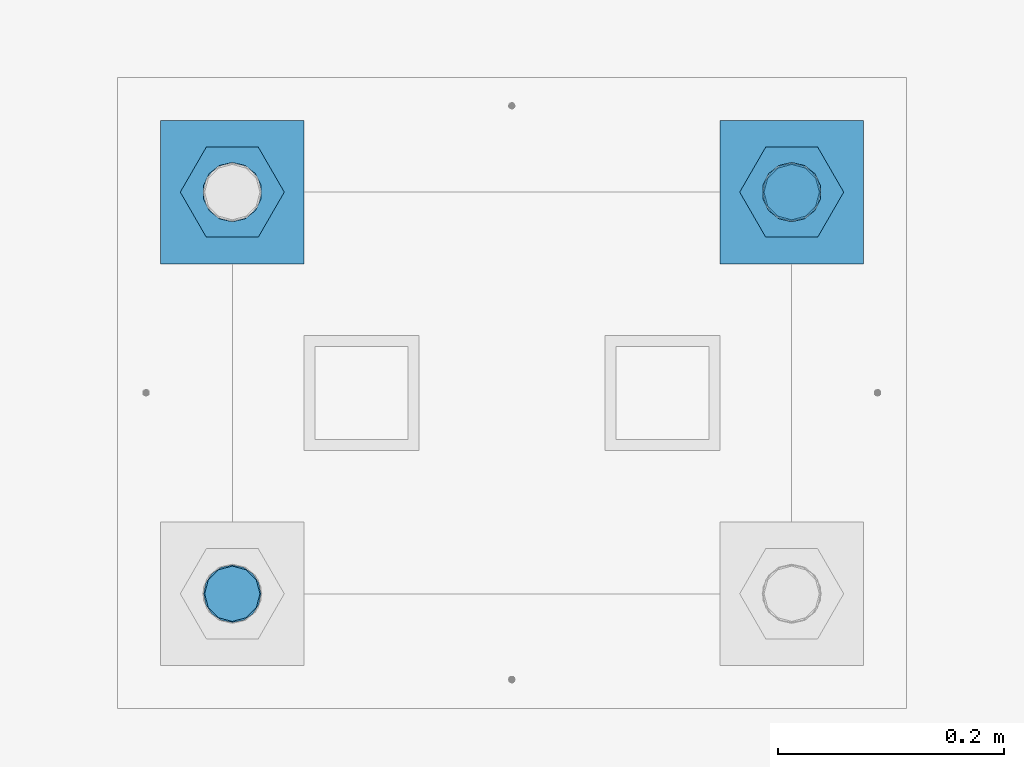
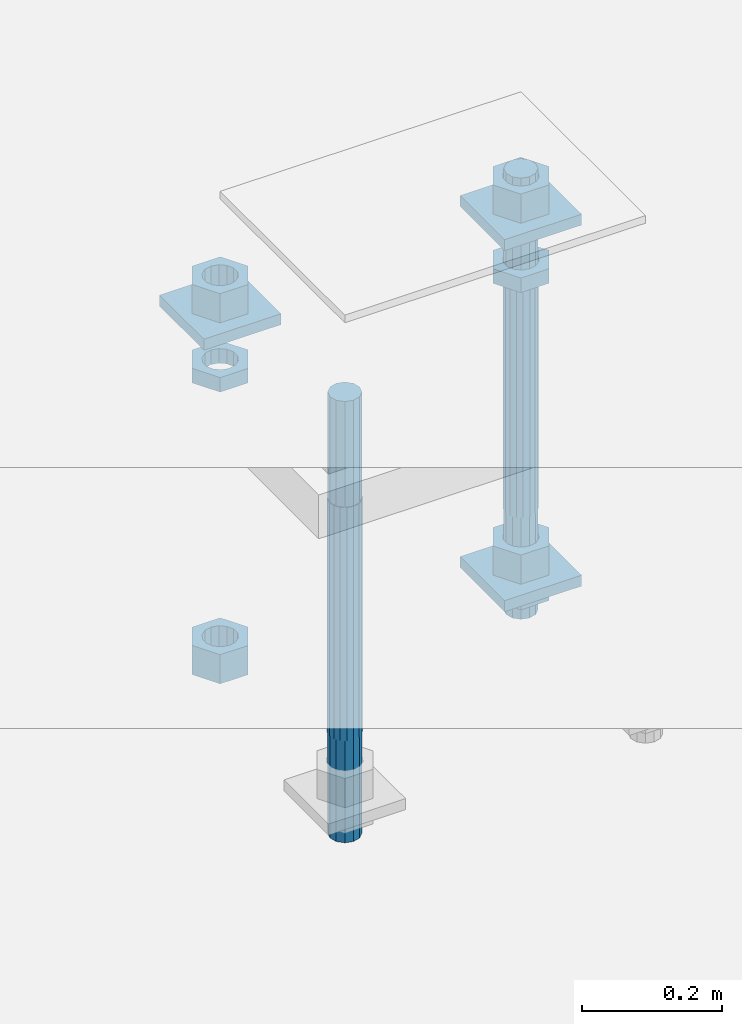
# One storey, part 2595 of 3843: 12 beams, 1 element without a shape of its own.
"""IFC2X3 building model written with IfcOpenShell, lengths in millimetres."""

from ifc_helpers import new_model, si_unit, frame, origin_with_axes, place, context, subcontext, project, spatial, faceted_brep, material, type_object, element, aggregate, save


model = new_model("IFC2X3")

# Units and contexts
model_context = context("Model", 3, precision=1e-05, world=origin_with_axes())
body_context = subcontext(model_context, "Body", "Model", "MODEL_VIEW")
ifc_project = project(units=[si_unit("LENGTHUNIT", "METRE", prefix="MILLI"), si_unit("AREAUNIT", "SQUARE_METRE"), si_unit("VOLUMEUNIT", "CUBIC_METRE"), si_unit("MASSUNIT", "GRAM", prefix="KILO"), si_unit("TIMEUNIT", "SECOND"), si_unit("PLANEANGLEUNIT", "RADIAN"), si_unit("SOLIDANGLEUNIT", "STERADIAN"), si_unit("THERMODYNAMICTEMPERATUREUNIT", "DEGREE_CELSIUS"), si_unit("LUMINOUSINTENSITYUNIT", "LUMEN")], contexts=[model_context])

# Site, building, storey
site_placement = place(None, origin_with_axes())
site = spatial("IfcSite", under=ifc_project, at=site_placement, CompositionType="ELEMENT")
building_placement = place(site_placement, origin_with_axes())
building = spatial("IfcBuilding", under=site, at=building_placement, Name="Undefined", CompositionType="ELEMENT")
storey_placement = place(building_placement, origin_with_axes())
storey = spatial("IfcBuildingStorey", under=building, at=storey_placement, Name="Undefined", CompositionType="ELEMENT", Elevation=0.0)

# Assembly, beams
assembly_placement = place(storey_placement, origin_with_axes())
assembly = element("IfcElementAssembly", 1, at=assembly_placement, inside=storey, Name="TEMPLATE", AssemblyPlace="NOTDEFINED", PredefinedType="RIGID_FRAME")
ifc_material_1 = material(Name="STEEL/A572-50")
beam_type_1 = type_object("IfcBeamType", PredefinedType="NOTDEFINED")
beam_1_placement = place(assembly_placement, frame((105403.65, 17957.7999984741, 29873.575), z_axis=(-1.0, 0.0, 0.0), x_axis=(0.0, -1.0, 0.0)))
beam_1 = element("IfcBeam", 2, at=beam_1_placement, type_object=beam_type_1, material=ifc_material_1, Name="WASHER_PLATE", context=body_context, shape_type="Brep", body=[
    faceted_brep([(0.0, 9.52500000000146, -63.5), (0.0, 9.52500000000146, 63.5), (127.0, 9.52500000000146, 63.5), (127.0, 9.52500000000146, -63.5), (0.0, -9.52500000000146, 63.5), (127.0, -9.52500000000146, 63.5), (0.0, -9.52500000000146, -63.5), (127.0, -9.52500000000146, -63.5)], [[[0, 1, 2, 3]], [[1, 4, 5, 2]], [[4, 6, 7, 5]], [[6, 0, 3, 7]], [[5, 7, 3, 2]], [[6, 4, 1, 0]]]),
])
beam_2_placement = place(assembly_placement, frame((104908.35, 17957.7999984741, 29873.575), z_axis=(-1.0, 0.0, 0.0), x_axis=(0.0, -1.0, 0.0)))
beam_2 = element("IfcBeam", 3, at=beam_2_placement, type_object=beam_type_1, material=ifc_material_1, Name="WASHER_PLATE", context=body_context, shape_type="Brep", body=[
    faceted_brep([(0.0, 9.52500000000146, -63.5), (0.0, 9.52500000000146, 63.5), (127.0, 9.52500000000146, 63.5), (127.0, 9.52500000000146, -63.5), (0.0, -9.52500000000146, 63.5), (127.0, -9.52500000000146, 63.5), (0.0, -9.52500000000146, -63.5), (127.0, -9.52500000000146, -63.5)], [[[0, 1, 2, 3]], [[1, 4, 5, 2]], [[4, 6, 7, 5]], [[6, 0, 3, 7]], [[5, 7, 3, 2]], [[6, 4, 1, 0]]]),
])
beam_3_placement = place(assembly_placement, frame((105403.65, 17957.7999984741, 29244.925), z_axis=(-1.0, 0.0, 0.0), x_axis=(0.0, -1.0, 0.0)))
beam_3 = element("IfcBeam", 4, at=beam_3_placement, type_object=beam_type_1, material=ifc_material_1, Name="WASHER_PLATE", context=body_context, shape_type="Brep", body=[
    faceted_brep([(0.0, 9.52500000000146, -63.5), (0.0, 9.52500000000146, 63.5), (127.0, 9.52500000000146, 63.5), (127.0, 9.52500000000146, -63.5), (0.0, -9.52500000000146, 63.5), (127.0, -9.52500000000146, 63.5), (0.0, -9.52500000000146, -63.5), (127.0, -9.52500000000146, -63.5)], [[[0, 1, 2, 3]], [[1, 4, 5, 2]], [[4, 6, 7, 5]], [[6, 0, 3, 7]], [[5, 7, 3, 2]], [[6, 4, 1, 0]]]),
])
ifc_material_2 = material(Name="STEEL/A36")
beam_type_2 = type_object("IfcBeamType", Name="2_HALF_NUT", PredefinedType="NOTDEFINED")
beam_4_placement = place(assembly_placement, frame((105403.65, 17894.2999984741, 29787.85), z_axis=(0.0, -1.0, 0.0), x_axis=(0.0, 0.0, -1.0)))
beam_4 = element("IfcBeam", 5, at=beam_4_placement, type_object=beam_type_2, material=ifc_material_2, Name="NUT", ObjectType="2_HALF_NUT", context=body_context, shape_type="Brep", body=[
    faceted_brep([(0.0, -46.0369987487793, 0.0), (0.0, -23.0184993743896, -39.869213104248), (25.4000000000015, -23.0184993743896, -39.869213104248), (25.4000000000015, -46.0369987487793, 0.0), (0.0, 23.0184993743896, -39.869213104248), (25.4000000000015, 23.0184993743896, -39.869213104248), (0.0, 46.0369987487793, 0.0), (25.4000000000015, 46.0369987487793, 0.0), (0.0, 23.0184993743896, 39.869213104248), (25.4000000000015, 23.0184993743896, 39.869213104248), (0.0, -23.0184993743896, 39.869213104248), (25.4000000000015, -23.0184993743896, 39.869213104248), (0.0, 0.0, 26.1940002441406), (0.0, 11.3650617044477, 23.5999013092805), (25.4000000000015, 11.3650617044477, 23.5999013092805), (25.4000000000015, 0.0, 26.1940002441406), (0.0, 20.4791109456419, 16.3316083006721), (25.4000000000015, 20.4791109456419, 16.3316083006721), (0.0, 25.5370200498292, 5.82867859874386), (25.4000000000015, 25.5370200498292, 5.82867859874386), (0.0, 25.5370200498292, -5.82867859874386), (25.4000000000015, 25.5370200498292, -5.82867859874386), (0.0, 20.4791109456419, -16.3316083006721), (25.4000000000015, 20.4791109456419, -16.3316083006721), (0.0, 11.3650617044477, -23.5999013092805), (25.4000000000015, 11.3650617044477, -23.5999013092805), (0.0, 0.0, -26.1940002441406), (25.4000000000015, 0.0, -26.1940002441406), (0.0, -11.3650617044477, -23.5999013092805), (25.4000000000015, -11.3650617044477, -23.5999013092805), (0.0, -20.4791109456419, -16.3316083006721), (25.4000000000015, -20.4791109456419, -16.3316083006721), (0.0, -25.5370200498292, -5.82867859874386), (25.4000000000015, -25.5370200498292, -5.82867859874386), (0.0, -25.5370200498292, 5.82867859874386), (25.4000000000015, -25.5370200498292, 5.82867859874386), (0.0, -20.4791109456419, 16.3316083006721), (25.4000000000015, -20.4791109456419, 16.3316083006721), (0.0, -11.3650617044477, 23.5999013092805), (25.4000000000015, -11.3650617044477, 23.5999013092805)], [[[0, 1, 2, 3]], [[1, 4, 5, 2]], [[4, 6, 7, 5]], [[6, 8, 9, 7]], [[8, 10, 11, 9]], [[10, 0, 3, 11]], [[12, 13, 14, 15]], [[13, 16, 17, 14]], [[16, 18, 19, 17]], [[18, 20, 21, 19]], [[20, 22, 23, 21]], [[22, 24, 25, 23]], [[24, 26, 27, 25]], [[26, 28, 29, 27]], [[28, 30, 31, 29]], [[30, 32, 33, 31]], [[32, 34, 35, 33]], [[34, 36, 37, 35]], [[36, 38, 39, 37]], [[38, 12, 15, 39]], [[5, 7, 9, 11, 3, 2], [17, 19, 21, 23, 25, 27, 29, 31, 33, 35, 37, 39, 15, 14]], [[10, 8, 6, 4, 1, 0], [38, 36, 34, 32, 30, 28, 26, 24, 22, 20, 18, 16, 13, 12]]]),
])
beam_5_placement = place(assembly_placement, frame((105403.65, 17894.2999984741, 29235.4), z_axis=(0.0, -1.0, 0.0), x_axis=(0.0, 0.0, -1.0)))
beam_5 = element("IfcBeam", 6, at=beam_5_placement, type_object=beam_type_2, material=ifc_material_2, Name="NUT", ObjectType="2_HALF_NUT", context=body_context, shape_type="Brep", body=[
    faceted_brep([(0.0, -46.0369987487793, 0.0), (0.0, -23.0184993743896, -39.869213104248), (25.4000000000015, -23.0184993743896, -39.869213104248), (25.4000000000015, -46.0369987487793, 0.0), (0.0, 23.0184993743896, -39.869213104248), (25.4000000000015, 23.0184993743896, -39.869213104248), (0.0, 46.0369987487793, 0.0), (25.4000000000015, 46.0369987487793, 0.0), (0.0, 23.0184993743896, 39.869213104248), (25.4000000000015, 23.0184993743896, 39.869213104248), (0.0, -23.0184993743896, 39.869213104248), (25.4000000000015, -23.0184993743896, 39.869213104248), (0.0, 0.0, 26.1940002441406), (0.0, 11.3650617044477, 23.5999013092805), (25.4000000000015, 11.3650617044477, 23.5999013092805), (25.4000000000015, 0.0, 26.1940002441406), (0.0, 20.4791109456419, 16.3316083006721), (25.4000000000015, 20.4791109456419, 16.3316083006721), (0.0, 25.5370200498292, 5.82867859874386), (25.4000000000015, 25.5370200498292, 5.82867859874386), (0.0, 25.5370200498292, -5.82867859874386), (25.4000000000015, 25.5370200498292, -5.82867859874386), (0.0, 20.4791109456419, -16.3316083006721), (25.4000000000015, 20.4791109456419, -16.3316083006721), (0.0, 11.3650617044477, -23.5999013092805), (25.4000000000015, 11.3650617044477, -23.5999013092805), (0.0, 0.0, -26.1940002441406), (25.4000000000015, 0.0, -26.1940002441406), (0.0, -11.3650617044477, -23.5999013092805), (25.4000000000015, -11.3650617044477, -23.5999013092805), (0.0, -20.4791109456419, -16.3316083006721), (25.4000000000015, -20.4791109456419, -16.3316083006721), (0.0, -25.5370200498292, -5.82867859874386), (25.4000000000015, -25.5370200498292, -5.82867859874386), (0.0, -25.5370200498292, 5.82867859874386), (25.4000000000015, -25.5370200498292, 5.82867859874386), (0.0, -20.4791109456419, 16.3316083006721), (25.4000000000015, -20.4791109456419, 16.3316083006721), (0.0, -11.3650617044477, 23.5999013092805), (25.4000000000015, -11.3650617044477, 23.5999013092805)], [[[0, 1, 2, 3]], [[1, 4, 5, 2]], [[4, 6, 7, 5]], [[6, 8, 9, 7]], [[8, 10, 11, 9]], [[10, 0, 3, 11]], [[12, 13, 14, 15]], [[13, 16, 17, 14]], [[16, 18, 19, 17]], [[18, 20, 21, 19]], [[20, 22, 23, 21]], [[22, 24, 25, 23]], [[24, 26, 27, 25]], [[26, 28, 29, 27]], [[28, 30, 31, 29]], [[30, 32, 33, 31]], [[32, 34, 35, 33]], [[34, 36, 37, 35]], [[36, 38, 39, 37]], [[38, 12, 15, 39]], [[5, 7, 9, 11, 3, 2], [17, 19, 21, 23, 25, 27, 29, 31, 33, 35, 37, 39, 15, 14]], [[10, 8, 6, 4, 1, 0], [38, 36, 34, 32, 30, 28, 26, 24, 22, 20, 18, 16, 13, 12]]]),
])
beam_6_placement = place(assembly_placement, frame((104908.35, 17894.2999984741, 29787.85), z_axis=(0.0, -1.0, 0.0), x_axis=(0.0, 0.0, -1.0)))
beam_6 = element("IfcBeam", 7, at=beam_6_placement, type_object=beam_type_2, material=ifc_material_2, Name="NUT", ObjectType="2_HALF_NUT", context=body_context, shape_type="Brep", body=[
    faceted_brep([(0.0, -46.0369987487793, 0.0), (0.0, -23.0184993743896, -39.869213104248), (25.4000000000015, -23.0184993743896, -39.869213104248), (25.4000000000015, -46.0369987487793, 0.0), (0.0, 23.0184993743896, -39.869213104248), (25.4000000000015, 23.0184993743896, -39.869213104248), (0.0, 46.0369987487793, 0.0), (25.4000000000015, 46.0369987487793, 0.0), (0.0, 23.0184993743896, 39.869213104248), (25.4000000000015, 23.0184993743896, 39.869213104248), (0.0, -23.0184993743896, 39.869213104248), (25.4000000000015, -23.0184993743896, 39.869213104248), (0.0, 0.0, 26.1940002441406), (0.0, 11.3650617044477, 23.5999013092805), (25.4000000000015, 11.3650617044477, 23.5999013092805), (25.4000000000015, 0.0, 26.1940002441406), (0.0, 20.4791109456419, 16.3316083006721), (25.4000000000015, 20.4791109456419, 16.3316083006721), (0.0, 25.5370200498292, 5.82867859874386), (25.4000000000015, 25.5370200498292, 5.82867859874386), (0.0, 25.5370200498292, -5.82867859874386), (25.4000000000015, 25.5370200498292, -5.82867859874386), (0.0, 20.4791109456419, -16.3316083006721), (25.4000000000015, 20.4791109456419, -16.3316083006721), (0.0, 11.3650617044477, -23.5999013092805), (25.4000000000015, 11.3650617044477, -23.5999013092805), (0.0, 0.0, -26.1940002441406), (25.4000000000015, 0.0, -26.1940002441406), (0.0, -11.3650617044477, -23.5999013092805), (25.4000000000015, -11.3650617044477, -23.5999013092805), (0.0, -20.4791109456419, -16.3316083006721), (25.4000000000015, -20.4791109456419, -16.3316083006721), (0.0, -25.5370200498292, -5.82867859874386), (25.4000000000015, -25.5370200498292, -5.82867859874386), (0.0, -25.5370200498292, 5.82867859874386), (25.4000000000015, -25.5370200498292, 5.82867859874386), (0.0, -20.4791109456419, 16.3316083006721), (25.4000000000015, -20.4791109456419, 16.3316083006721), (0.0, -11.3650617044477, 23.5999013092805), (25.4000000000015, -11.3650617044477, 23.5999013092805)], [[[0, 1, 2, 3]], [[1, 4, 5, 2]], [[4, 6, 7, 5]], [[6, 8, 9, 7]], [[8, 10, 11, 9]], [[10, 0, 3, 11]], [[12, 13, 14, 15]], [[13, 16, 17, 14]], [[16, 18, 19, 17]], [[18, 20, 21, 19]], [[20, 22, 23, 21]], [[22, 24, 25, 23]], [[24, 26, 27, 25]], [[26, 28, 29, 27]], [[28, 30, 31, 29]], [[30, 32, 33, 31]], [[32, 34, 35, 33]], [[34, 36, 37, 35]], [[36, 38, 39, 37]], [[38, 12, 15, 39]], [[5, 7, 9, 11, 3, 2], [17, 19, 21, 23, 25, 27, 29, 31, 33, 35, 37, 39, 15, 14]], [[10, 8, 6, 4, 1, 0], [38, 36, 34, 32, 30, 28, 26, 24, 22, 20, 18, 16, 13, 12]]]),
])
beam_type_3 = type_object("IfcBeamType", Name="2_HEAVY_HEX_NUT", PredefinedType="NOTDEFINED")
beam_7_placement = place(assembly_placement, frame((105403.65, 17894.2999984741, 29933.9), z_axis=(0.0, -1.0, 0.0), x_axis=(0.0, 0.0, -1.0)))
beam_7 = element("IfcBeam", 8, at=beam_7_placement, type_object=beam_type_3, material=ifc_material_2, Name="NUT", ObjectType="2_HEAVY_HEX_NUT", context=body_context, shape_type="Brep", body=[
    faceted_brep([(0.0, -46.0369987487793, 0.0), (0.0, -23.0184993743896, -39.869213104248), (50.7999999999993, -23.0184993743896, -39.869213104248), (50.7999999999993, -46.0369987487793, 0.0), (0.0, 23.0184993743896, -39.869213104248), (50.7999999999993, 23.0184993743896, -39.869213104248), (0.0, 46.0369987487793, 0.0), (50.7999999999993, 46.0369987487793, 0.0), (0.0, 23.0184993743896, 39.869213104248), (50.7999999999993, 23.0184993743896, 39.869213104248), (0.0, -23.0184993743896, 39.869213104248), (50.7999999999993, -23.0184993743896, 39.869213104248), (0.0, 0.0, 26.1940002441406), (0.0, 11.3650617044477, 23.5999013092805), (50.7999999999993, 11.3650617044477, 23.5999013092805), (50.7999999999993, 0.0, 26.1940002441406), (0.0, 20.4791109456419, 16.3316083006721), (50.7999999999993, 20.4791109456419, 16.3316083006721), (0.0, 25.5370200498292, 5.82867859874386), (50.7999999999993, 25.5370200498292, 5.82867859874386), (0.0, 25.5370200498292, -5.82867859874386), (50.7999999999993, 25.5370200498292, -5.82867859874386), (0.0, 20.4791109456419, -16.3316083006721), (50.7999999999993, 20.4791109456419, -16.3316083006721), (0.0, 11.3650617044477, -23.5999013092805), (50.7999999999993, 11.3650617044477, -23.5999013092805), (0.0, 0.0, -26.1940002441406), (50.7999999999993, 0.0, -26.1940002441406), (0.0, -11.3650617044477, -23.5999013092805), (50.7999999999993, -11.3650617044477, -23.5999013092805), (0.0, -20.4791109456419, -16.3316083006721), (50.7999999999993, -20.4791109456419, -16.3316083006721), (0.0, -25.5370200498292, -5.82867859874386), (50.7999999999993, -25.5370200498292, -5.82867859874386), (0.0, -25.5370200498292, 5.82867859874386), (50.7999999999993, -25.5370200498292, 5.82867859874386), (0.0, -20.4791109456419, 16.3316083006721), (50.7999999999993, -20.4791109456419, 16.3316083006721), (0.0, -11.3650617044477, 23.5999013092805), (50.7999999999993, -11.3650617044477, 23.5999013092805)], [[[0, 1, 2, 3]], [[1, 4, 5, 2]], [[4, 6, 7, 5]], [[6, 8, 9, 7]], [[8, 10, 11, 9]], [[10, 0, 3, 11]], [[12, 13, 14, 15]], [[13, 16, 17, 14]], [[16, 18, 19, 17]], [[18, 20, 21, 19]], [[20, 22, 23, 21]], [[22, 24, 25, 23]], [[24, 26, 27, 25]], [[26, 28, 29, 27]], [[28, 30, 31, 29]], [[30, 32, 33, 31]], [[32, 34, 35, 33]], [[34, 36, 37, 35]], [[36, 38, 39, 37]], [[38, 12, 15, 39]], [[5, 7, 9, 11, 3, 2], [17, 19, 21, 23, 25, 27, 29, 31, 33, 35, 37, 39, 15, 14]], [[10, 8, 6, 4, 1, 0], [38, 36, 34, 32, 30, 28, 26, 24, 22, 20, 18, 16, 13, 12]]]),
])
beam_8_placement = place(assembly_placement, frame((105403.65, 17894.2999984741, 29305.25), z_axis=(0.0, -1.0, 0.0), x_axis=(0.0, 0.0, -1.0)))
beam_8 = element("IfcBeam", 9, at=beam_8_placement, type_object=beam_type_3, material=ifc_material_2, Name="NUT", ObjectType="2_HEAVY_HEX_NUT", context=body_context, shape_type="Brep", body=[
    faceted_brep([(0.0, -46.0369987487793, 0.0), (0.0, -23.0184993743896, -39.869213104248), (50.7999999999993, -23.0184993743896, -39.869213104248), (50.7999999999993, -46.0369987487793, 0.0), (0.0, 23.0184993743896, -39.869213104248), (50.7999999999993, 23.0184993743896, -39.869213104248), (0.0, 46.0369987487793, 0.0), (50.7999999999993, 46.0369987487793, 0.0), (0.0, 23.0184993743896, 39.869213104248), (50.7999999999993, 23.0184993743896, 39.869213104248), (0.0, -23.0184993743896, 39.869213104248), (50.7999999999993, -23.0184993743896, 39.869213104248), (0.0, 0.0, 26.1940002441406), (0.0, 11.3650617044477, 23.5999013092805), (50.7999999999993, 11.3650617044477, 23.5999013092805), (50.7999999999993, 0.0, 26.1940002441406), (0.0, 20.4791109456419, 16.3316083006721), (50.7999999999993, 20.4791109456419, 16.3316083006721), (0.0, 25.5370200498292, 5.82867859874386), (50.7999999999993, 25.5370200498292, 5.82867859874386), (0.0, 25.5370200498292, -5.82867859874386), (50.7999999999993, 25.5370200498292, -5.82867859874386), (0.0, 20.4791109456419, -16.3316083006721), (50.7999999999993, 20.4791109456419, -16.3316083006721), (0.0, 11.3650617044477, -23.5999013092805), (50.7999999999993, 11.3650617044477, -23.5999013092805), (0.0, 0.0, -26.1940002441406), (50.7999999999993, 0.0, -26.1940002441406), (0.0, -11.3650617044477, -23.5999013092805), (50.7999999999993, -11.3650617044477, -23.5999013092805), (0.0, -20.4791109456419, -16.3316083006721), (50.7999999999993, -20.4791109456419, -16.3316083006721), (0.0, -25.5370200498292, -5.82867859874386), (50.7999999999993, -25.5370200498292, -5.82867859874386), (0.0, -25.5370200498292, 5.82867859874386), (50.7999999999993, -25.5370200498292, 5.82867859874386), (0.0, -20.4791109456419, 16.3316083006721), (50.7999999999993, -20.4791109456419, 16.3316083006721), (0.0, -11.3650617044477, 23.5999013092805), (50.7999999999993, -11.3650617044477, 23.5999013092805)], [[[0, 1, 2, 3]], [[1, 4, 5, 2]], [[4, 6, 7, 5]], [[6, 8, 9, 7]], [[8, 10, 11, 9]], [[10, 0, 3, 11]], [[12, 13, 14, 15]], [[13, 16, 17, 14]], [[16, 18, 19, 17]], [[18, 20, 21, 19]], [[20, 22, 23, 21]], [[22, 24, 25, 23]], [[24, 26, 27, 25]], [[26, 28, 29, 27]], [[28, 30, 31, 29]], [[30, 32, 33, 31]], [[32, 34, 35, 33]], [[34, 36, 37, 35]], [[36, 38, 39, 37]], [[38, 12, 15, 39]], [[5, 7, 9, 11, 3, 2], [17, 19, 21, 23, 25, 27, 29, 31, 33, 35, 37, 39, 15, 14]], [[10, 8, 6, 4, 1, 0], [38, 36, 34, 32, 30, 28, 26, 24, 22, 20, 18, 16, 13, 12]]]),
])
beam_9_placement = place(assembly_placement, frame((104908.35, 17894.2999984741, 29933.9), z_axis=(0.0, -1.0, 0.0), x_axis=(0.0, 0.0, -1.0)))
beam_9 = element("IfcBeam", 10, at=beam_9_placement, type_object=beam_type_3, material=ifc_material_2, Name="NUT", ObjectType="2_HEAVY_HEX_NUT", context=body_context, shape_type="Brep", body=[
    faceted_brep([(0.0, -46.0369987487793, 0.0), (0.0, -23.0184993743896, -39.869213104248), (50.7999999999993, -23.0184993743896, -39.869213104248), (50.7999999999993, -46.0369987487793, 0.0), (0.0, 23.0184993743896, -39.869213104248), (50.7999999999993, 23.0184993743896, -39.869213104248), (0.0, 46.0369987487793, 0.0), (50.7999999999993, 46.0369987487793, 0.0), (0.0, 23.0184993743896, 39.869213104248), (50.7999999999993, 23.0184993743896, 39.869213104248), (0.0, -23.0184993743896, 39.869213104248), (50.7999999999993, -23.0184993743896, 39.869213104248), (0.0, 0.0, 26.1940002441406), (0.0, 11.3650617044477, 23.5999013092805), (50.7999999999993, 11.3650617044477, 23.5999013092805), (50.7999999999993, 0.0, 26.1940002441406), (0.0, 20.4791109456419, 16.3316083006721), (50.7999999999993, 20.4791109456419, 16.3316083006721), (0.0, 25.5370200498292, 5.82867859874386), (50.7999999999993, 25.5370200498292, 5.82867859874386), (0.0, 25.5370200498292, -5.82867859874386), (50.7999999999993, 25.5370200498292, -5.82867859874386), (0.0, 20.4791109456419, -16.3316083006721), (50.7999999999993, 20.4791109456419, -16.3316083006721), (0.0, 11.3650617044477, -23.5999013092805), (50.7999999999993, 11.3650617044477, -23.5999013092805), (0.0, 0.0, -26.1940002441406), (50.7999999999993, 0.0, -26.1940002441406), (0.0, -11.3650617044477, -23.5999013092805), (50.7999999999993, -11.3650617044477, -23.5999013092805), (0.0, -20.4791109456419, -16.3316083006721), (50.7999999999993, -20.4791109456419, -16.3316083006721), (0.0, -25.5370200498292, -5.82867859874386), (50.7999999999993, -25.5370200498292, -5.82867859874386), (0.0, -25.5370200498292, 5.82867859874386), (50.7999999999993, -25.5370200498292, 5.82867859874386), (0.0, -20.4791109456419, 16.3316083006721), (50.7999999999993, -20.4791109456419, 16.3316083006721), (0.0, -11.3650617044477, 23.5999013092805), (50.7999999999993, -11.3650617044477, 23.5999013092805)], [[[0, 1, 2, 3]], [[1, 4, 5, 2]], [[4, 6, 7, 5]], [[6, 8, 9, 7]], [[8, 10, 11, 9]], [[10, 0, 3, 11]], [[12, 13, 14, 15]], [[13, 16, 17, 14]], [[16, 18, 19, 17]], [[18, 20, 21, 19]], [[20, 22, 23, 21]], [[22, 24, 25, 23]], [[24, 26, 27, 25]], [[26, 28, 29, 27]], [[28, 30, 31, 29]], [[30, 32, 33, 31]], [[32, 34, 35, 33]], [[34, 36, 37, 35]], [[36, 38, 39, 37]], [[38, 12, 15, 39]], [[5, 7, 9, 11, 3, 2], [17, 19, 21, 23, 25, 27, 29, 31, 33, 35, 37, 39, 15, 14]], [[10, 8, 6, 4, 1, 0], [38, 36, 34, 32, 30, 28, 26, 24, 22, 20, 18, 16, 13, 12]]]),
])
beam_10_placement = place(assembly_placement, frame((104908.35, 17894.2999984741, 29305.25), z_axis=(0.0, -1.0, 0.0), x_axis=(0.0, 0.0, -1.0)))
beam_10 = element("IfcBeam", 11, at=beam_10_placement, type_object=beam_type_3, material=ifc_material_2, Name="NUT", ObjectType="2_HEAVY_HEX_NUT", context=body_context, shape_type="Brep", body=[
    faceted_brep([(0.0, -46.0369987487793, 0.0), (0.0, -23.0184993743896, -39.869213104248), (50.7999999999993, -23.0184993743896, -39.869213104248), (50.7999999999993, -46.0369987487793, 0.0), (0.0, 23.0184993743896, -39.869213104248), (50.7999999999993, 23.0184993743896, -39.869213104248), (0.0, 46.0369987487793, 0.0), (50.7999999999993, 46.0369987487793, 0.0), (0.0, 23.0184993743896, 39.869213104248), (50.7999999999993, 23.0184993743896, 39.869213104248), (0.0, -23.0184993743896, 39.869213104248), (50.7999999999993, -23.0184993743896, 39.869213104248), (0.0, 0.0, 26.1940002441406), (0.0, 11.3650617044477, 23.5999013092805), (50.7999999999993, 11.3650617044477, 23.5999013092805), (50.7999999999993, 0.0, 26.1940002441406), (0.0, 20.4791109456419, 16.3316083006721), (50.7999999999993, 20.4791109456419, 16.3316083006721), (0.0, 25.5370200498292, 5.82867859874386), (50.7999999999993, 25.5370200498292, 5.82867859874386), (0.0, 25.5370200498292, -5.82867859874386), (50.7999999999993, 25.5370200498292, -5.82867859874386), (0.0, 20.4791109456419, -16.3316083006721), (50.7999999999993, 20.4791109456419, -16.3316083006721), (0.0, 11.3650617044477, -23.5999013092805), (50.7999999999993, 11.3650617044477, -23.5999013092805), (0.0, 0.0, -26.1940002441406), (50.7999999999993, 0.0, -26.1940002441406), (0.0, -11.3650617044477, -23.5999013092805), (50.7999999999993, -11.3650617044477, -23.5999013092805), (0.0, -20.4791109456419, -16.3316083006721), (50.7999999999993, -20.4791109456419, -16.3316083006721), (0.0, -25.5370200498292, -5.82867859874386), (50.7999999999993, -25.5370200498292, -5.82867859874386), (0.0, -25.5370200498292, 5.82867859874386), (50.7999999999993, -25.5370200498292, 5.82867859874386), (0.0, -20.4791109456419, 16.3316083006721), (50.7999999999993, -20.4791109456419, 16.3316083006721), (0.0, -11.3650617044477, 23.5999013092805), (50.7999999999993, -11.3650617044477, 23.5999013092805)], [[[0, 1, 2, 3]], [[1, 4, 5, 2]], [[4, 6, 7, 5]], [[6, 8, 9, 7]], [[8, 10, 11, 9]], [[10, 0, 3, 11]], [[12, 13, 14, 15]], [[13, 16, 17, 14]], [[16, 18, 19, 17]], [[18, 20, 21, 19]], [[20, 22, 23, 21]], [[22, 24, 25, 23]], [[24, 26, 27, 25]], [[26, 28, 29, 27]], [[28, 30, 31, 29]], [[30, 32, 33, 31]], [[32, 34, 35, 33]], [[34, 36, 37, 35]], [[36, 38, 39, 37]], [[38, 12, 15, 39]], [[5, 7, 9, 11, 3, 2], [17, 19, 21, 23, 25, 27, 29, 31, 33, 35, 37, 39, 15, 14]], [[10, 8, 6, 4, 1, 0], [38, 36, 34, 32, 30, 28, 26, 24, 22, 20, 18, 16, 13, 12]]]),
])
ifc_material_3 = material()
beam_type_4 = type_object("IfcBeamType", PredefinedType="NOTDEFINED")
beam_11_placement = place(assembly_placement, frame((105403.65, 17894.2999984741, 29762.45), z_axis=(0.0, -1.0, 0.0), x_axis=(0.0, 0.0, -1.0)))
beam_11 = element("IfcBeam", 12, at=beam_11_placement, type_object=beam_type_4, material=ifc_material_3, Name="ANCHOR_ROD", context=body_context, shape_type="Brep", body=[
    faceted_brep([(-184.150000000001, -21.217622392709, 12.25), (-184.150000000001, -12.2499999999854, 21.2176223927163), (-184.150000000001, 1.45519152283669e-11, 24.5), (-184.150000000001, 12.2500000000146, 21.2176223927163), (-184.150000000001, 21.2176223927381, 12.25), (-184.150000000001, 24.5000000000146, 0.0), (-184.150000000001, 21.2176223927381, -12.25), (-184.150000000001, 12.2500000000146, -21.2176223927163), (-184.150000000001, 1.45519152283669e-11, -24.5), (-184.150000000001, -12.2499999999854, -21.2176223927163), (-184.150000000001, -21.217622392709, -12.25), (-184.150000000001, -24.4999999999854, 0.0), (0.0, 24.5000000000146, 0.0), (0.0, 21.2176223927381, -12.25), (0.0, 12.2500000000146, -21.2176223927163), (0.0, 1.45519152283669e-11, -24.5), (0.0, -12.2499999999854, -21.2176223927163), (0.0, -21.217622392709, -12.25), (0.0, -24.4999999999854, 0.0), (0.0, -21.217622392709, 12.25), (0.0, -12.2499999999854, 21.2176223927163), (0.0, 1.45519152283669e-11, 24.5), (0.0, 12.2500000000146, 21.2176223927163), (0.0, 21.2176223927381, 12.25), (0.0, -23.4665401257807, 9.72015918207035), (0.0, -17.9605122421344, 17.9605122421417), (0.0, -9.72015918207762, 23.466540125788), (0.0, 0.0, 25.4000000000015), (0.0, 9.72015918207762, 23.466540125788), (0.0, 17.9605122421344, 17.9605122421417), (0.0, 23.4665401257807, 9.72015918207035), (0.0, 25.3999996185303, 0.0), (0.0, 23.4665401257807, -9.72015918207035), (0.0, 17.9605122421344, -17.9605122421417), (0.0, 9.72015918207762, -23.466540125788), (0.0, 0.0, -25.4000000000015), (0.0, -9.72015918207762, -23.466540125788), (0.0, -17.9605122421344, -17.9605122421417), (0.0, -23.4665401257807, -9.72015918207035), (0.0, -25.3999996185303, 0.0), (406.399999999998, -25.3999999999942, 0.0), (406.399999999998, -23.4665401257807, 9.72015918207035), (406.399999999998, -17.9605122421344, 17.9605122421417), (406.399999999998, -9.72015918207762, 23.466540125788), (406.399999999998, 0.0, 25.4000000000015), (406.399999999998, 9.72015918207762, 23.466540125788), (406.399999999998, 17.9605122421344, 17.9605122421417), (406.399999999998, 23.4665401257807, 9.72015918207035), (406.399999999998, 25.3999999999942, 0.0), (406.399999999998, 23.4665401257807, -9.72015918207035), (406.399999999998, 17.9605122421344, -17.9605122421417), (406.399999999998, 9.72015918207762, -23.466540125788), (406.399999999998, 0.0, -25.4000000000015), (406.399999999998, -9.72015918207762, -23.466540125788), (406.399999999998, -17.9605122421344, -17.9605122421417), (406.399999999998, -23.4665401257807, -9.72015918207035), (406.399999999998, -12.2499999999854, 21.2176223927163), (406.399999999998, 1.45519152283669e-11, 24.5), (406.399999999998, 12.2500000000146, 21.2176223927163), (406.399999999998, 21.2176223927381, 12.25), (406.399999999998, 24.5000000000146, 0.0), (406.399999999998, 21.2176223927381, -12.25), (406.399999999998, 12.2500000000146, -21.2176223927163), (406.399999999998, 1.45519152283669e-11, -24.5), (406.399999999998, -12.2499999999854, -21.2176223927163), (406.399999999998, -21.217622392709, -12.25), (406.399999999998, -24.4999999999854, 0.0), (406.399999999998, -21.217622392709, 12.25), (584.200000000001, -12.2499999999854, -21.2176223927163), (584.200000000001, 1.45519152283669e-11, -24.5), (584.200000000001, 12.2500000000146, -21.2176223927163), (584.200000000001, 21.2176223927381, -12.25), (584.200000000001, 24.5000000000146, 0.0), (584.200000000001, 21.2176223927381, 12.25), (584.200000000001, 12.2500000000146, 21.2176223927163), (584.200000000001, 1.45519152283669e-11, 24.5), (584.200000000001, -12.2499999999854, 21.2176223927163), (584.200000000001, -21.217622392709, 12.25), (584.200000000001, -24.4999999999854, 0.0), (584.200000000001, -21.217622392709, -12.25)], [[[0, 1, 2, 3, 4, 5, 6, 7, 8, 9, 10, 11]], [[6, 5, 12, 13]], [[7, 6, 13, 14]], [[8, 7, 14, 15]], [[9, 8, 15, 16]], [[10, 9, 16, 17]], [[11, 10, 17, 18]], [[0, 11, 18, 19]], [[1, 0, 19, 20]], [[2, 1, 20, 21]], [[3, 2, 21, 22]], [[4, 3, 22, 23]], [[5, 4, 23, 12]], [[24, 25, 26, 27, 28, 29, 30, 31, 32, 33, 34, 35, 36, 37, 38, 39], [22, 21, 20, 19, 18, 17, 16, 15, 14, 13, 12, 23]], [[24, 39, 40, 41]], [[25, 24, 41, 42]], [[26, 25, 42, 43]], [[27, 26, 43, 44]], [[28, 27, 44, 45]], [[29, 28, 45, 46]], [[30, 29, 46, 47]], [[31, 30, 47, 48]], [[32, 31, 48, 49]], [[33, 32, 49, 50]], [[34, 33, 50, 51]], [[35, 34, 51, 52]], [[36, 35, 52, 53]], [[37, 36, 53, 54]], [[38, 37, 54, 55]], [[39, 38, 55, 40]], [[54, 53, 52, 51, 50, 49, 48, 47, 46, 45, 44, 43, 42, 41, 40, 55], [56, 57, 58, 59, 60, 61, 62, 63, 64, 65, 66, 67]], [[68, 69, 70, 71, 72, 73, 74, 75, 76, 77, 78, 79]], [[76, 75, 57, 56]], [[77, 76, 56, 67]], [[78, 77, 67, 66]], [[79, 78, 66, 65]], [[68, 79, 65, 64]], [[69, 68, 64, 63]], [[70, 69, 63, 62]], [[71, 70, 62, 61]], [[72, 71, 61, 60]], [[73, 72, 60, 59]], [[74, 73, 59, 58]], [[75, 74, 58, 57]]]),
])
beam_12_placement = place(assembly_placement, frame((104908.35, 17538.6999984741, 29762.45), z_axis=(0.0, -1.0, 0.0), x_axis=(0.0, 0.0, -1.0)))
beam_12 = element("IfcBeam", 13, at=beam_12_placement, type_object=beam_type_4, material=ifc_material_3, Name="ANCHOR_ROD", context=body_context, shape_type="Brep", body=[
    faceted_brep([(-184.150000000001, -21.217622392709, 12.25), (-184.150000000001, -12.2499999999854, 21.2176223927163), (-184.150000000001, 1.45519152283669e-11, 24.5), (-184.150000000001, 12.2500000000146, 21.2176223927163), (-184.150000000001, 21.2176223927381, 12.25), (-184.150000000001, 24.5000000000146, 0.0), (-184.150000000001, 21.2176223927381, -12.25), (-184.150000000001, 12.2500000000146, -21.2176223927163), (-184.150000000001, 1.45519152283669e-11, -24.5), (-184.150000000001, -12.2499999999854, -21.2176223927163), (-184.150000000001, -21.217622392709, -12.25), (-184.150000000001, -24.4999999999854, 0.0), (0.0, 24.5000000000146, 0.0), (0.0, 21.2176223927381, -12.25), (0.0, 12.2500000000146, -21.2176223927163), (0.0, 1.45519152283669e-11, -24.5), (0.0, -12.2499999999854, -21.2176223927163), (0.0, -21.217622392709, -12.25), (0.0, -24.4999999999854, 0.0), (0.0, -21.217622392709, 12.25), (0.0, -12.2499999999854, 21.2176223927163), (0.0, 1.45519152283669e-11, 24.5), (0.0, 12.2500000000146, 21.2176223927163), (0.0, 21.2176223927381, 12.25), (0.0, -23.4665401257807, 9.72015918207035), (0.0, -17.9605122421344, 17.9605122421417), (0.0, -9.72015918207762, 23.466540125788), (0.0, 0.0, 25.4000000000015), (0.0, 9.72015918207762, 23.466540125788), (0.0, 17.9605122421344, 17.9605122421417), (0.0, 23.4665401257807, 9.72015918207035), (0.0, 25.3999996185303, 0.0), (0.0, 23.4665401257807, -9.72015918207035), (0.0, 17.9605122421344, -17.9605122421417), (0.0, 9.72015918207762, -23.466540125788), (0.0, 0.0, -25.4000000000015), (0.0, -9.72015918207762, -23.466540125788), (0.0, -17.9605122421344, -17.9605122421417), (0.0, -23.4665401257807, -9.72015918207035), (0.0, -25.3999996185303, 0.0), (406.399999999998, -25.3999999999942, 0.0), (406.399999999998, -23.4665401257807, 9.72015918207035), (406.399999999998, -17.9605122421344, 17.9605122421417), (406.399999999998, -9.72015918207762, 23.466540125788), (406.399999999998, 0.0, 25.4000000000015), (406.399999999998, 9.72015918207762, 23.466540125788), (406.399999999998, 17.9605122421344, 17.9605122421417), (406.399999999998, 23.4665401257807, 9.72015918207035), (406.399999999998, 25.3999999999942, 0.0), (406.399999999998, 23.4665401257807, -9.72015918207035), (406.399999999998, 17.9605122421344, -17.9605122421417), (406.399999999998, 9.72015918207762, -23.466540125788), (406.399999999998, 0.0, -25.4000000000015), (406.399999999998, -9.72015918207762, -23.466540125788), (406.399999999998, -17.9605122421344, -17.9605122421417), (406.399999999998, -23.4665401257807, -9.72015918207035), (406.399999999998, -12.2499999999854, 21.2176223927163), (406.399999999998, 1.45519152283669e-11, 24.5), (406.399999999998, 12.2500000000146, 21.2176223927163), (406.399999999998, 21.2176223927381, 12.25), (406.399999999998, 24.5000000000146, 0.0), (406.399999999998, 21.2176223927381, -12.25), (406.399999999998, 12.2500000000146, -21.2176223927163), (406.399999999998, 1.45519152283669e-11, -24.5), (406.399999999998, -12.2499999999854, -21.2176223927163), (406.399999999998, -21.217622392709, -12.25), (406.399999999998, -24.4999999999854, 0.0), (406.399999999998, -21.217622392709, 12.25), (584.200000000001, -12.2499999999854, -21.2176223927163), (584.200000000001, 1.45519152283669e-11, -24.5), (584.200000000001, 12.2500000000146, -21.2176223927163), (584.200000000001, 21.2176223927381, -12.25), (584.200000000001, 24.5000000000146, 0.0), (584.200000000001, 21.2176223927381, 12.25), (584.200000000001, 12.2500000000146, 21.2176223927163), (584.200000000001, 1.45519152283669e-11, 24.5), (584.200000000001, -12.2499999999854, 21.2176223927163), (584.200000000001, -21.217622392709, 12.25), (584.200000000001, -24.4999999999854, 0.0), (584.200000000001, -21.217622392709, -12.25)], [[[0, 1, 2, 3, 4, 5, 6, 7, 8, 9, 10, 11]], [[6, 5, 12, 13]], [[7, 6, 13, 14]], [[8, 7, 14, 15]], [[9, 8, 15, 16]], [[10, 9, 16, 17]], [[11, 10, 17, 18]], [[0, 11, 18, 19]], [[1, 0, 19, 20]], [[2, 1, 20, 21]], [[3, 2, 21, 22]], [[4, 3, 22, 23]], [[5, 4, 23, 12]], [[24, 25, 26, 27, 28, 29, 30, 31, 32, 33, 34, 35, 36, 37, 38, 39], [22, 21, 20, 19, 18, 17, 16, 15, 14, 13, 12, 23]], [[24, 39, 40, 41]], [[25, 24, 41, 42]], [[26, 25, 42, 43]], [[27, 26, 43, 44]], [[28, 27, 44, 45]], [[29, 28, 45, 46]], [[30, 29, 46, 47]], [[31, 30, 47, 48]], [[32, 31, 48, 49]], [[33, 32, 49, 50]], [[34, 33, 50, 51]], [[35, 34, 51, 52]], [[36, 35, 52, 53]], [[37, 36, 53, 54]], [[38, 37, 54, 55]], [[39, 38, 55, 40]], [[54, 53, 52, 51, 50, 49, 48, 47, 46, 45, 44, 43, 42, 41, 40, 55], [56, 57, 58, 59, 60, 61, 62, 63, 64, 65, 66, 67]], [[68, 69, 70, 71, 72, 73, 74, 75, 76, 77, 78, 79]], [[76, 75, 57, 56]], [[77, 76, 56, 67]], [[78, 77, 67, 66]], [[79, 78, 66, 65]], [[68, 79, 65, 64]], [[69, 68, 64, 63]], [[70, 69, 63, 62]], [[71, 70, 62, 61]], [[72, 71, 61, 60]], [[73, 72, 60, 59]], [[74, 73, 59, 58]], [[75, 74, 58, 57]]]),
])
aggregate(assembly, [beam_1, beam_2, beam_4, beam_7, beam_8, beam_5, beam_3, beam_11, beam_6, beam_9, beam_10, beam_12])

save(model, "model.ifc")
